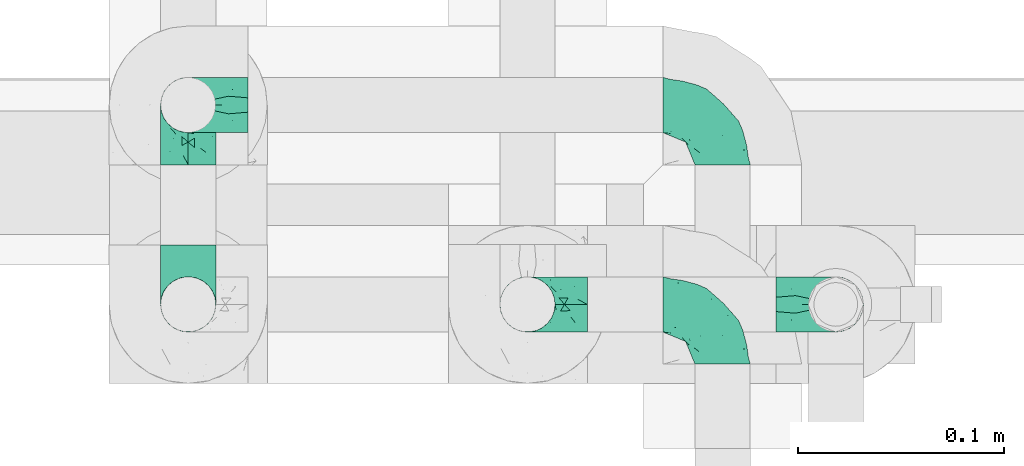
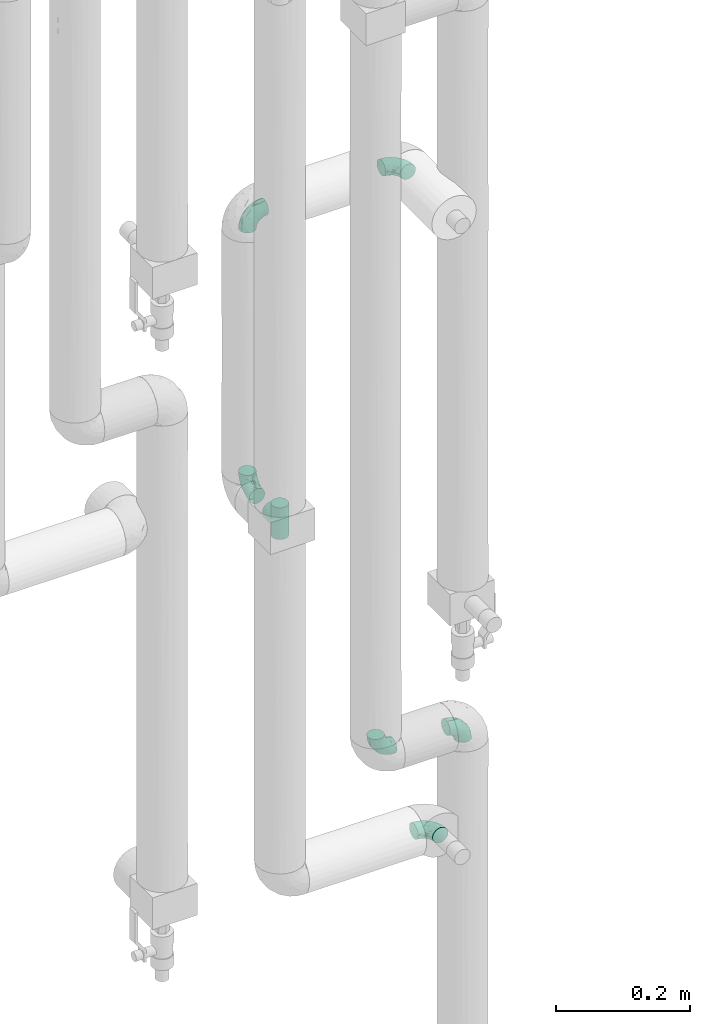
# One storey, part 755 of 827: 7 flow fittings.
"""IFC2X3 building model written with IfcOpenShell, lengths in millimetres."""

from ifc_helpers import new_model, entity, si_unit, converted_unit, derived_unit, direction, frame, origin, place, context, subcontext, project, spatial, faceted_brep, source, transform, mapped, material, type_object, type_shapes, element, save


model = new_model("IFC2X3")

# Units and contexts
model_context = context("Model", 3, precision=0.01, world=origin(), true_north=direction((6.12303176911189e-17, 1.0)))
body_context = subcontext(model_context, "Body", "Model", "MODEL_VIEW")
ifc_project = project(units=[si_unit("LENGTHUNIT", "METRE", prefix="MILLI"), si_unit("AREAUNIT", "SQUARE_METRE"), si_unit("VOLUMEUNIT", "CUBIC_METRE"), converted_unit("PLANEANGLEUNIT", "DEGREE", entity("IfcRatioMeasure", 0.0174532925199433), si_unit("PLANEANGLEUNIT", "RADIAN"), dimensions=[0, 0, 0, 0, 0, 0, 0]), si_unit("MASSUNIT", "GRAM", prefix="KILO"), derived_unit("MASSDENSITYUNIT", [(si_unit("MASSUNIT", "GRAM", prefix="KILO"), 1), (si_unit("LENGTHUNIT", "METRE"), -3)]), derived_unit("MOMENTOFINERTIAUNIT", [(si_unit("LENGTHUNIT", "METRE"), 4)]), si_unit("TIMEUNIT", "SECOND"), si_unit("FREQUENCYUNIT", "HERTZ"), si_unit("THERMODYNAMICTEMPERATUREUNIT", "DEGREE_CELSIUS"), derived_unit("THERMALTRANSMITTANCEUNIT", [(si_unit("MASSUNIT", "GRAM", prefix="KILO"), 1), (si_unit("THERMODYNAMICTEMPERATUREUNIT", "KELVIN"), -1), (si_unit("TIMEUNIT", "SECOND"), -3)]), derived_unit("VOLUMETRICFLOWRATEUNIT", [(si_unit("LENGTHUNIT", "METRE"), 3), (si_unit("TIMEUNIT", "SECOND"), -1)]), derived_unit("MASSFLOWRATEUNIT", [(si_unit("MASSUNIT", "GRAM", prefix="KILO"), 1), (si_unit("TIMEUNIT", "SECOND"), -1)]), derived_unit("ROTATIONALFREQUENCYUNIT", [(si_unit("TIMEUNIT", "SECOND"), -1)]), si_unit("ELECTRICCURRENTUNIT", "AMPERE"), si_unit("ELECTRICVOLTAGEUNIT", "VOLT"), si_unit("POWERUNIT", "WATT"), si_unit("FORCEUNIT", "NEWTON", prefix="KILO"), si_unit("ILLUMINANCEUNIT", "LUX"), si_unit("LUMINOUSFLUXUNIT", "LUMEN"), si_unit("LUMINOUSINTENSITYUNIT", "CANDELA"), derived_unit("USERDEFINED", [(si_unit("MASSUNIT", "GRAM", prefix="KILO"), -1), (si_unit("LENGTHUNIT", "METRE"), -2), (si_unit("TIMEUNIT", "SECOND"), 3), (si_unit("LUMINOUSFLUXUNIT", "LUMEN"), 1)]), derived_unit("LINEARVELOCITYUNIT", [(si_unit("LENGTHUNIT", "METRE"), 1), (si_unit("TIMEUNIT", "SECOND"), -1)]), si_unit("PRESSUREUNIT", "PASCAL"), derived_unit("USERDEFINED", [(si_unit("LENGTHUNIT", "METRE"), -2), (si_unit("MASSUNIT", "GRAM", prefix="KILO"), 1), (si_unit("TIMEUNIT", "SECOND"), -2)]), derived_unit("LINEARFORCEUNIT", [(si_unit("MASSUNIT", "GRAM", prefix="KILO"), 1), (si_unit("LENGTHUNIT", "METRE"), 1), (si_unit("TIMEUNIT", "SECOND"), -2), (si_unit("LENGTHUNIT", "METRE"), -1)]), derived_unit("PLANARFORCEUNIT", [(si_unit("MASSUNIT", "GRAM", prefix="KILO"), 1), (si_unit("LENGTHUNIT", "METRE"), 1), (si_unit("TIMEUNIT", "SECOND"), -2), (si_unit("LENGTHUNIT", "METRE"), -2)])], contexts=[model_context])

# Site, building, storey
site_placement = place(None, origin())
site = spatial("IfcSite", under=ifc_project, at=site_placement, CompositionType="ELEMENT")
building_placement = place(site_placement, origin())
building = spatial("IfcBuilding", under=site, at=building_placement, CompositionType="ELEMENT")
storey_placement = place(building_placement, frame((0.0, 0.0, 28200.0)))
storey = spatial("IfcBuildingStorey", under=building, at=storey_placement, Name="08", CompositionType="ELEMENT", Elevation=28200.0)

# Flow fittings
ifc_material = material()
pipe_fitting_type_1 = type_object("IfcPipeFittingType", Name="ADSK_1", PredefinedType="NOTDEFINED", material=ifc_material)
shared_shape_1 = source(origin(), body_context, "Body", "Brep", [
    faceted_brep([(-29.1, 0.0, -13.45), (-29.1, -3.48, -12.99), (-29.1, -6.73, -11.65), (-29.1, -9.51, -9.51), (-29.1, -11.65, -6.73), (-29.1, -12.99, -3.48), (-29.1, -13.45, 0.0), (-29.1, -12.99, 3.48), (-29.1, -11.65, 6.72), (-29.1, -9.51, 9.51), (-29.1, -6.73, 11.65), (-29.1, -3.48, 12.99), (-29.1, 0.0, 13.45), (-29.1, 3.48, 12.99), (-29.1, 6.72, 11.65), (-29.1, 9.51, 9.51), (-29.1, 11.65, 6.72), (-29.1, 12.99, 3.48), (-29.1, 13.45, 0.0), (-29.1, 12.99, -3.48), (-29.1, 11.65, -6.73), (-29.1, 9.51, -9.51), (-29.1, 6.72, -11.65), (-29.1, 3.48, -12.99), (-3.48, 29.1, -12.99), (-6.72, 29.1, -11.65), (-9.51, 29.1, -9.51), (-11.65, 29.1, -6.73), (-12.99, 29.1, -3.48), (-13.45, 29.1, 0.0), (-12.99, 29.1, 3.48), (-11.65, 29.1, 6.72), (-9.51, 29.1, 9.51), (-6.72, 29.1, 11.65), (-3.48, 29.1, 12.99), (0.0, 29.1, 13.45), (3.48, 29.1, 12.99), (6.73, 29.1, 11.65), (9.51, 29.1, 9.51), (11.65, 29.1, 6.72), (12.99, 29.1, 3.48), (13.45, 29.1, 0.0), (12.99, 29.1, -3.48), (11.65, 29.1, -6.73), (9.51, 29.1, -9.51), (6.73, 29.1, -11.65), (3.48, 29.1, -12.99), (0.0, 29.1, -13.45), (-19.62, -11.66, 4.28), (-21.41, -10.36, 7.6), (-16.26, -10.01, 0.0), (-12.48, -9.76, 2.75), (-10.66, 15.6, 11.91), (-15.27, 9.55, 12.42), (-10.71, 10.71, 13.09), (-0.04, 0.04, 0.0), (0.49, -0.45, 4.38), (-3.67, -4.15, 4.26), (-22.68, -11.73, 0.0), (-21.45, -4.97, 12.13), (-11.59, -2.84, 11.28), (-14.77, 0.17, 13.07), (-19.08, -7.58, 10.06), (-22.36, -1.69, 13.23), (-20.49, 2.21, 13.42), (-7.82, -7.75, 0.0), (-5.53, -2.55, 8.58), (-1.33, -0.87, 6.53), (-1.15, 1.15, 8.49), (-22.46, 5.38, 12.69), (-14.04, 21.05, 6.04), (-3.19, 3.19, 11.14), (-5.08, 25.05, 12.59), (-1.97, 21.79, 13.41), (-22.68, 11.31, 8.78), (-18.16, 12.64, 9.68), (-20.46, 14.33, 6.11), (-4.13, 10.11, 13.26), (-7.66, 3.08, 12.63), (-2.02, 8.24, 12.45), (-24.91, 8.22, 10.95), (-5.08, 14.28, 13.42), (-8.96, 6.48, 13.4), (-19.7, 16.14, 3.1), (-18.03, 18.03, 0.0), (-23.05, 15.96, 0.0), (-25.26, 12.69, 5.56), (4.97, 21.45, 12.13), (7.58, 19.08, 10.06), (1.69, 22.36, 13.23), (10.36, 21.41, 7.6), (8.11, 12.69, 6.86), (11.66, 19.62, 4.28), (-6.03, 19.65, 12.79), (9.76, 12.48, 2.75), (10.01, 16.26, 0.0), (-14.58, 16.06, 9.44), (-11.19, 23.14, 8.74), (-16.29, 16.8, 7.24), (-11.99, -5.68, 9.36), (-15.42, 20.78, 3.08), (5.79, 12.02, 9.27), (2.84, 11.59, 11.28), (2.55, 5.53, 8.58), (-15.74, 23.57, 0.0), (-15.96, 23.05, 0.0), (-24.62, 13.88, 2.39), (-8.61, 22.49, 11.12), (-14.98, 12.8, 11.14), (11.73, 22.68, 0.0), (-12.69, -8.11, 6.86), (7.75, 7.82, 0.0), (-15.98, 6.12, 13.19), (-14.48, 3.64, 13.45), (-19.6, 9.46, 11.31), (-8.3, 15.02, 12.85), (-0.17, 14.77, 13.07), (-6.9, -5.2, 6.52), (7.5, 8.93, 4.46), (5.22, 6.95, 6.56), (-8.85, -7.47, 4.42), (3.86, 3.93, 0.0), (4.18, 3.75, 4.31), (-23.57, 15.74, 0.0), (-3.93, -3.86, 0.0), (-21.79, 1.97, -13.41), (-11.31, 22.68, -8.78), (-14.33, 20.46, -6.11), (-12.69, 25.26, -5.56), (4.97, 21.45, -12.13), (2.84, 11.59, -11.28), (-0.17, 14.77, -13.07), (-25.05, 5.08, -12.59), (-16.8, 16.29, -7.24), (-20.78, 15.42, -3.08), (-16.14, 19.7, -3.1), (-12.02, -5.79, -9.27), (-11.59, -2.84, -11.28), (-5.53, -2.55, -8.58), (-23.14, 11.19, -8.74), (-22.49, 8.61, -11.12), (-1.33, -0.87, -6.53), (-3.67, -4.15, -4.26), (-6.9, -5.2, -6.52), (-19.65, 6.03, -12.79), (-15.6, 10.66, -11.91), (-14.28, 5.08, -13.42), (-10.71, 10.71, -13.09), (-6.48, 8.96, -13.4), (-19.62, -11.66, -4.28), (-21.41, -10.36, -7.6), (-12.48, -9.76, -2.75), (11.66, 19.62, -4.28), (-12.69, -8.11, -6.86), (-22.36, -1.69, -13.23), (-16.06, 14.58, -9.44), (5.68, 11.99, -9.36), (7.58, 19.08, -10.06), (-19.08, -7.58, -10.06), (-21.45, -4.97, -12.13), (-9.55, 15.27, -12.42), (-12.8, 14.98, -11.14), (-8.22, 24.91, -10.95), (10.36, 21.41, -7.6), (-5.38, 22.46, -12.69), (1.69, 22.36, -13.23), (-2.21, 20.49, -13.42), (-12.64, 18.16, -9.68), (-21.05, 14.04, -6.04), (9.76, 12.48, -2.75), (-10.11, 4.13, -13.26), (-3.08, 7.66, -12.63), (-8.24, 2.02, -12.45), (-13.88, 24.62, -2.39), (8.11, 12.69, -6.86), (-6.12, 15.98, -13.19), (-3.64, 14.48, -13.45), (-9.46, 19.6, -11.31), (-15.02, 8.3, -12.85), (-14.77, 0.17, -13.07), (-3.19, 3.19, -11.14), (5.22, 6.95, -6.56), (2.55, 5.53, -8.58), (0.49, -0.45, -4.38), (4.18, 3.75, -4.31), (-8.85, -7.47, -4.42), (-1.15, 1.15, -8.49), (7.5, 8.93, -4.46)], [[[0, 1, 2, 3, 4, 5, 6, 7, 8, 9, 10, 11, 12, 13, 14, 15, 16, 17, 18, 19, 20, 21, 22, 23]], [[24, 25, 26, 27, 28, 29, 30, 31, 32, 33, 34, 35, 36, 37, 38, 39, 40, 41, 42, 43, 44, 45, 46, 47]], [[48, 49, 8]], [[48, 50, 51]], [[52, 53, 54]], [[55, 56, 57]], [[49, 9, 8]], [[58, 48, 7]], [[59, 60, 61]], [[62, 10, 9]], [[62, 59, 10]], [[12, 63, 64]], [[51, 50, 65]], [[66, 67, 68]], [[12, 11, 63]], [[69, 14, 13]], [[31, 30, 70]], [[66, 71, 60]], [[34, 72, 73]], [[74, 75, 76]], [[77, 78, 79]], [[14, 80, 15]], [[16, 15, 74]], [[81, 54, 82]], [[83, 84, 85]], [[74, 76, 86]], [[37, 87, 88]], [[88, 38, 37]], [[36, 35, 89]], [[90, 91, 92]], [[93, 81, 73]], [[35, 34, 73]], [[10, 59, 11]], [[92, 94, 95]], [[96, 97, 98]], [[90, 92, 39]], [[99, 60, 62]], [[40, 39, 92]], [[87, 37, 36]], [[100, 84, 83]], [[50, 48, 58]], [[100, 83, 98]], [[101, 102, 103]], [[104, 105, 84, 100, 29]], [[48, 8, 7]], [[86, 17, 16]], [[106, 18, 17]], [[32, 97, 107]], [[53, 52, 108]], [[52, 93, 107]], [[97, 96, 107]], [[72, 107, 93]], [[72, 34, 33]], [[92, 109, 40]], [[33, 32, 107]], [[69, 13, 64]], [[88, 87, 102]], [[12, 64, 13]], [[49, 110, 62]], [[39, 38, 90]], [[95, 94, 111]], [[112, 113, 82]], [[53, 69, 112]], [[80, 74, 15]], [[114, 108, 75]], [[32, 31, 97]], [[115, 52, 54]], [[93, 115, 81]], [[89, 73, 116]], [[106, 76, 83]], [[106, 83, 85]], [[83, 76, 98]], [[100, 30, 29]], [[60, 59, 62]], [[63, 59, 61]], [[110, 117, 99]], [[60, 71, 78]], [[89, 87, 36]], [[116, 79, 102]], [[116, 102, 87]], [[102, 71, 103]], [[110, 49, 48]], [[62, 9, 49]], [[38, 88, 90]], [[91, 90, 88]], [[112, 69, 64]], [[80, 69, 114]], [[111, 94, 118]], [[119, 101, 103]], [[117, 66, 99]], [[117, 120, 57]], [[119, 91, 101]], [[66, 68, 71]], [[66, 117, 67]], [[121, 111, 122, 55]], [[56, 55, 122]], [[31, 70, 97]], [[97, 70, 98]], [[107, 96, 52]], [[53, 108, 114]], [[112, 82, 54]], [[116, 73, 81]], [[78, 82, 61]], [[81, 82, 77]], [[73, 89, 35]], [[87, 89, 116]], [[59, 63, 11]], [[64, 63, 61]], [[112, 64, 113]], [[53, 112, 54]], [[7, 6, 58]], [[109, 92, 95]], [[109, 41, 40]], [[69, 53, 114]], [[52, 96, 108]], [[75, 108, 96]], [[75, 96, 98]], [[114, 75, 74]], [[64, 61, 113]], [[61, 82, 113]], [[91, 88, 101]], [[110, 48, 51]], [[92, 91, 94]], [[91, 119, 118]], [[106, 85, 123, 18]], [[106, 17, 86]], [[60, 78, 61]], [[79, 78, 71]], [[102, 79, 71]], [[77, 79, 116]], [[81, 77, 116]], [[78, 77, 82]], [[69, 80, 14]], [[74, 80, 114]], [[74, 86, 16]], [[106, 86, 76]], [[107, 72, 33]], [[73, 72, 93]], [[98, 70, 100]], [[75, 98, 76]], [[30, 100, 70]], [[110, 99, 62]], [[66, 60, 99]], [[120, 110, 51]], [[67, 117, 57]], [[57, 56, 67]], [[67, 122, 119]], [[110, 120, 117]], [[65, 120, 51]], [[57, 65, 124, 55]], [[122, 67, 56]], [[67, 103, 68]], [[71, 68, 103]], [[65, 57, 120]], [[102, 101, 88]], [[67, 119, 103]], [[118, 119, 122]], [[118, 122, 111]], [[91, 118, 94]], [[81, 115, 54]], [[93, 52, 115]], [[23, 125, 0]], [[126, 127, 128]], [[129, 130, 131]], [[23, 22, 132]], [[133, 134, 135]], [[136, 137, 138]], [[21, 139, 140]], [[141, 142, 143]], [[144, 140, 145]], [[143, 136, 138]], [[146, 147, 148]], [[144, 132, 140]], [[5, 4, 149]], [[4, 3, 150]], [[45, 129, 46]], [[151, 50, 149]], [[152, 43, 42]], [[42, 41, 109]], [[150, 149, 4]], [[153, 149, 150]], [[154, 1, 0]], [[139, 155, 140]], [[156, 130, 157]], [[149, 58, 5]], [[18, 123, 85, 84, 134]], [[158, 159, 137]], [[84, 105, 135]], [[160, 145, 161]], [[143, 153, 136]], [[27, 26, 126]], [[25, 162, 26]], [[152, 163, 43]], [[25, 24, 164]], [[47, 165, 166]], [[158, 3, 2]], [[167, 127, 126]], [[20, 19, 168]], [[47, 46, 165]], [[44, 157, 45]], [[23, 132, 125]], [[44, 43, 163]], [[158, 2, 159]], [[47, 166, 24]], [[129, 45, 157]], [[164, 24, 166]], [[134, 84, 135]], [[95, 169, 152]], [[22, 21, 140]], [[144, 146, 125]], [[109, 152, 42]], [[95, 152, 109]], [[170, 171, 172]], [[155, 139, 133]], [[28, 27, 128]], [[159, 2, 1]], [[173, 29, 28]], [[50, 151, 65]], [[169, 95, 111]], [[163, 174, 157]], [[175, 176, 148]], [[160, 164, 175]], [[162, 126, 26]], [[177, 161, 167]], [[21, 20, 139]], [[144, 145, 178]], [[144, 178, 146]], [[154, 125, 179]], [[173, 127, 135]], [[173, 135, 105]], [[135, 127, 133]], [[134, 19, 18]], [[154, 159, 1]], [[179, 172, 137]], [[179, 137, 159]], [[137, 180, 138]], [[130, 129, 157]], [[165, 129, 131]], [[174, 181, 156]], [[130, 180, 171]], [[3, 158, 150]], [[153, 150, 158]], [[174, 163, 152]], [[157, 44, 163]], [[175, 164, 166]], [[162, 164, 177]], [[130, 182, 180]], [[181, 141, 182]], [[55, 183, 184]], [[65, 151, 185]], [[183, 55, 142]], [[156, 181, 182]], [[180, 182, 186]], [[181, 187, 184]], [[65, 142, 55, 124]], [[20, 168, 139]], [[139, 168, 133]], [[140, 155, 145]], [[160, 161, 177]], [[175, 148, 147]], [[179, 125, 146]], [[171, 148, 131]], [[146, 148, 170]], [[125, 154, 0]], [[159, 154, 179]], [[129, 165, 46]], [[166, 165, 131]], [[175, 166, 176]], [[160, 175, 147]], [[58, 149, 50]], [[58, 6, 5]], [[145, 160, 147]], [[164, 160, 177]], [[145, 155, 161]], [[167, 161, 155]], [[167, 155, 133]], [[177, 167, 126]], [[166, 131, 176]], [[131, 148, 176]], [[149, 153, 151]], [[153, 143, 185]], [[145, 147, 178]], [[174, 152, 169]], [[173, 105, 104, 29]], [[173, 28, 128]], [[130, 171, 131]], [[172, 171, 180]], [[137, 172, 180]], [[170, 172, 179]], [[146, 170, 179]], [[171, 170, 148]], [[164, 162, 25]], [[126, 162, 177]], [[126, 128, 27]], [[173, 128, 127]], [[140, 132, 22]], [[125, 132, 144]], [[133, 168, 134]], [[167, 133, 127]], [[19, 134, 168]], [[153, 158, 136]], [[137, 136, 158]], [[141, 143, 138]], [[185, 143, 142]], [[186, 141, 138]], [[183, 142, 141]], [[185, 142, 65]], [[153, 185, 151]], [[180, 186, 138]], [[182, 141, 186]], [[141, 184, 183]], [[184, 111, 121, 55]], [[174, 156, 157]], [[182, 130, 156]], [[187, 174, 169]], [[141, 181, 184]], [[174, 187, 181]], [[111, 187, 169]], [[111, 184, 187]], [[146, 178, 147]]]),
])
type_shapes(pipe_fitting_type_1, [shared_shape_1])
for number, where, z_axis, x_axis, name in (
    (1, (35142.88, 14924.91, 1230.0), (0.0, 1.0, 0.0), (1.0, 0.0, 0.0), "ADSK_1"),
    (2, (34992.88, 14924.91, 1230.0), (0.0, 1.0, 0.0), (-1.0, 0.0, 0.0), "ADSK_1"),
):
    element("IfcFlowFitting", number, at=place(storey_placement, frame(where, z_axis=z_axis, x_axis=x_axis)), inside=storey, type_object=pipe_fitting_type_1, material=ifc_material, Name=name, ObjectType="ADSK_1", context=body_context, shape_type="MappedRepresentation", body=[
        mapped(shared_shape_1, transform((0.0, 0.0, 0.0), scale=1.0)),
    ])
pipe_fitting_type_2 = type_object("IfcPipeFittingType", Name="ADSK_1", PredefinedType="NOTDEFINED", material=ifc_material)
shared_shape_2 = source(origin(), body_context, "Body", "Brep", [
    faceted_brep([(-29.1, -3.48, -12.99), (-29.1, -6.72, -11.65), (-29.1, -9.51, -9.51), (-29.1, -11.65, -6.73), (-29.1, -12.99, -3.48), (-29.1, -13.45, 0.0), (-29.1, -12.99, 3.48), (-29.1, -11.65, 6.72), (-29.1, -9.51, 9.51), (-29.1, -6.72, 11.65), (-29.1, -3.48, 12.99), (-29.1, 0.0, 13.45), (-29.1, 3.48, 12.99), (-29.1, 6.73, 11.65), (-29.1, 9.51, 9.51), (-29.1, 11.65, 6.72), (-29.1, 12.99, 3.48), (-29.1, 13.45, 0.0), (-29.1, 12.99, -3.48), (-29.1, 11.65, -6.73), (-29.1, 9.51, -9.51), (-29.1, 6.73, -11.65), (-29.1, 3.48, -12.99), (-29.1, 0.0, -13.45), (0.0, -29.1, -13.45), (3.48, -29.1, -12.99), (6.73, -29.1, -11.65), (9.51, -29.1, -9.51), (11.65, -29.1, -6.73), (12.99, -29.1, -3.48), (13.45, -29.1, 0.0), (12.99, -29.1, 3.48), (11.65, -29.1, 6.72), (9.51, -29.1, 9.51), (6.73, -29.1, 11.65), (3.48, -29.1, 12.99), (0.0, -29.1, 13.45), (-3.48, -29.1, 12.99), (-6.72, -29.1, 11.65), (-9.51, -29.1, 9.51), (-11.65, -29.1, 6.72), (-12.99, -29.1, 3.48), (-13.45, -29.1, 0.0), (-12.99, -29.1, -3.48), (-11.65, -29.1, -6.73), (-9.51, -29.1, -9.51), (-6.72, -29.1, -11.65), (-3.48, -29.1, -12.99), (-21.41, 10.36, 7.6), (-19.62, 11.66, 4.28), (-12.48, 9.76, 2.75), (-16.26, 10.01, 0.0), (-10.71, -10.71, 13.09), (-15.27, -9.55, 12.42), (-10.66, -15.6, 11.91), (-3.67, 4.15, 4.26), (0.49, 0.45, 4.38), (-0.04, -0.04, 0.0), (-22.68, 11.73, 0.0), (-14.77, -0.17, 13.07), (-11.59, 2.84, 11.28), (-21.45, 4.97, 12.13), (-19.08, 7.58, 10.06), (-20.49, -2.21, 13.42), (-22.36, 1.69, 13.23), (-7.82, 7.75, 0.0), (-1.15, -1.15, 8.49), (-1.33, 0.87, 6.53), (-5.53, 2.55, 8.58), (-22.46, -5.38, 12.69), (-14.04, -21.05, 6.04), (-3.19, -3.19, 11.14), (-1.97, -21.79, 13.41), (-5.08, -25.05, 12.59), (-20.46, -14.33, 6.11), (-18.16, -12.64, 9.68), (-22.68, -11.31, 8.78), (-2.02, -8.24, 12.45), (-7.66, -3.08, 12.63), (-4.13, -10.11, 13.26), (-24.91, -8.22, 10.95), (-8.96, -6.48, 13.4), (-5.08, -14.28, 13.42), (-23.05, -15.96, 0.0), (-18.03, -18.03, 0.0), (-19.7, -16.14, 3.1), (-25.26, -12.69, 5.56), (7.58, -19.08, 10.06), (4.97, -21.45, 12.13), (1.69, -22.36, 13.23), (11.66, -19.62, 4.28), (8.11, -12.69, 6.86), (10.36, -21.41, 7.6), (-6.03, -19.65, 12.79), (10.01, -16.26, 0.0), (9.76, -12.48, 2.75), (-16.29, -16.8, 7.24), (-11.19, -23.14, 8.74), (-14.58, -16.06, 9.44), (-11.99, 5.68, 9.36), (-15.42, -20.78, 3.08), (2.55, -5.53, 8.58), (2.84, -11.59, 11.28), (5.79, -12.02, 9.27), (-15.96, -23.05, 0.0), (-15.74, -23.57, 0.0), (-24.62, -13.88, 2.39), (-8.61, -22.49, 11.12), (-14.98, -12.8, 11.14), (11.73, -22.68, 0.0), (-12.69, 8.11, 6.86), (7.75, -7.82, 0.0), (-14.48, -3.64, 13.45), (-15.98, -6.12, 13.19), (-19.6, -9.46, 11.31), (-8.3, -15.02, 12.85), (-0.17, -14.77, 13.07), (-6.9, 5.2, 6.52), (7.5, -8.93, 4.46), (5.22, -6.95, 6.56), (-8.85, 7.47, 4.42), (4.18, -3.75, 4.31), (3.86, -3.93, 0.0), (-23.57, -15.74, 0.0), (-3.93, 3.86, 0.0), (-21.79, -1.97, -13.41), (-12.69, -25.26, -5.56), (-14.33, -20.46, -6.11), (-11.31, -22.68, -8.78), (-0.17, -14.77, -13.07), (2.84, -11.59, -11.28), (4.97, -21.45, -12.13), (-25.05, -5.08, -12.59), (-16.14, -19.7, -3.1), (-20.78, -15.42, -3.08), (-16.8, -16.29, -7.24), (-5.53, 2.55, -8.58), (-11.59, 2.84, -11.28), (-12.02, 5.79, -9.27), (-22.49, -8.61, -11.12), (-23.14, -11.19, -8.74), (-6.9, 5.2, -6.52), (-3.67, 4.15, -4.26), (-1.33, 0.87, -6.53), (-15.6, -10.66, -11.91), (-19.65, -6.03, -12.79), (-6.48, -8.96, -13.4), (-10.71, -10.71, -13.09), (-14.28, -5.08, -13.42), (-19.62, 11.66, -4.28), (-21.41, 10.36, -7.6), (-12.48, 9.76, -2.75), (11.66, -19.62, -4.28), (-12.69, 8.11, -6.86), (-22.36, 1.69, -13.23), (-16.06, -14.58, -9.44), (7.58, -19.08, -10.06), (5.68, -11.99, -9.36), (-21.45, 4.97, -12.13), (-19.08, 7.58, -10.06), (-12.8, -14.98, -11.14), (-9.55, -15.27, -12.42), (-8.22, -24.91, -10.95), (10.36, -21.41, -7.6), (-5.38, -22.46, -12.69), (-2.21, -20.49, -13.42), (1.69, -22.36, -13.23), (-12.64, -18.16, -9.68), (-21.05, -14.04, -6.04), (9.76, -12.48, -2.75), (-8.24, -2.02, -12.45), (-3.08, -7.66, -12.63), (-10.11, -4.13, -13.26), (-13.88, -24.62, -2.39), (8.11, -12.69, -6.86), (-3.64, -14.48, -13.45), (-6.12, -15.98, -13.19), (-9.46, -19.6, -11.31), (-15.02, -8.3, -12.85), (-14.77, -0.17, -13.07), (-3.19, -3.19, -11.14), (5.22, -6.95, -6.56), (2.55, -5.53, -8.58), (4.18, -3.75, -4.31), (0.49, 0.45, -4.38), (-8.85, 7.47, -4.42), (-1.15, -1.15, -8.49), (7.5, -8.93, -4.46)], [[[0, 1, 2, 3, 4, 5, 6, 7, 8, 9, 10, 11, 12, 13, 14, 15, 16, 17, 18, 19, 20, 21, 22, 23]], [[24, 25, 26, 27, 28, 29, 30, 31, 32, 33, 34, 35, 36, 37, 38, 39, 40, 41, 42, 43, 44, 45, 46, 47]], [[15, 48, 49]], [[50, 51, 49]], [[52, 53, 54]], [[55, 56, 57]], [[15, 14, 48]], [[16, 49, 58]], [[59, 60, 61]], [[14, 13, 62]], [[13, 61, 62]], [[63, 64, 11]], [[65, 51, 50]], [[66, 67, 68]], [[64, 12, 11]], [[10, 9, 69]], [[70, 41, 40]], [[60, 71, 68]], [[72, 73, 37]], [[74, 75, 76]], [[77, 78, 79]], [[8, 80, 9]], [[76, 8, 7]], [[81, 52, 82]], [[83, 84, 85]], [[86, 74, 76]], [[87, 88, 34]], [[34, 33, 87]], [[89, 36, 35]], [[90, 91, 92]], [[72, 82, 93]], [[72, 37, 36]], [[12, 61, 13]], [[94, 95, 90]], [[96, 97, 98]], [[32, 90, 92]], [[62, 60, 99]], [[90, 32, 31]], [[35, 34, 88]], [[85, 84, 100]], [[58, 49, 51]], [[96, 85, 100]], [[101, 102, 103]], [[42, 100, 84, 104, 105]], [[16, 15, 49]], [[7, 6, 86]], [[6, 5, 106]], [[107, 97, 39]], [[108, 54, 53]], [[107, 93, 54]], [[107, 98, 97]], [[93, 107, 73]], [[38, 37, 73]], [[31, 109, 90]], [[107, 39, 38]], [[63, 10, 69]], [[102, 88, 87]], [[10, 63, 11]], [[62, 110, 48]], [[92, 33, 32]], [[111, 95, 94]], [[81, 112, 113]], [[113, 69, 53]], [[8, 76, 80]], [[75, 108, 114]], [[97, 40, 39]], [[52, 54, 115]], [[82, 115, 93]], [[116, 72, 89]], [[85, 74, 106]], [[83, 85, 106]], [[96, 74, 85]], [[42, 41, 100]], [[62, 61, 60]], [[59, 61, 64]], [[99, 117, 110]], [[78, 71, 60]], [[35, 88, 89]], [[102, 77, 116]], [[88, 102, 116]], [[101, 71, 102]], [[49, 48, 110]], [[48, 14, 62]], [[92, 87, 33]], [[87, 92, 91]], [[63, 69, 113]], [[114, 69, 80]], [[118, 95, 111]], [[101, 103, 119]], [[99, 68, 117]], [[55, 120, 117]], [[103, 91, 119]], [[71, 66, 68]], [[67, 117, 68]], [[121, 111, 122, 57]], [[121, 57, 56]], [[97, 70, 40]], [[96, 70, 97]], [[54, 98, 107]], [[114, 108, 53]], [[52, 81, 113]], [[82, 72, 116]], [[59, 81, 78]], [[79, 81, 82]], [[36, 89, 72]], [[116, 89, 88]], [[12, 64, 61]], [[59, 64, 63]], [[112, 63, 113]], [[52, 113, 53]], [[58, 17, 16]], [[94, 90, 109]], [[31, 30, 109]], [[114, 53, 69]], [[108, 98, 54]], [[98, 108, 75]], [[96, 98, 75]], [[76, 75, 114]], [[112, 59, 63]], [[112, 81, 59]], [[103, 87, 91]], [[50, 49, 110]], [[95, 91, 90]], [[118, 119, 91]], [[106, 5, 123, 83]], [[86, 6, 106]], [[59, 78, 60]], [[71, 78, 77]], [[71, 77, 102]], [[116, 77, 79]], [[116, 79, 82]], [[81, 79, 78]], [[9, 80, 69]], [[114, 80, 76]], [[7, 86, 76]], [[74, 86, 106]], [[38, 73, 107]], [[93, 73, 72]], [[100, 70, 96]], [[74, 96, 75]], [[70, 100, 41]], [[62, 99, 110]], [[99, 60, 68]], [[50, 110, 120]], [[55, 117, 67]], [[67, 56, 55]], [[119, 121, 67]], [[117, 120, 110]], [[50, 120, 65]], [[124, 65, 55, 57]], [[56, 67, 121]], [[66, 101, 67]], [[101, 66, 71]], [[120, 55, 65]], [[87, 103, 102]], [[101, 119, 67]], [[121, 119, 118]], [[111, 121, 118]], [[95, 118, 91]], [[52, 115, 82]], [[115, 54, 93]], [[23, 125, 0]], [[126, 127, 128]], [[129, 130, 131]], [[132, 1, 0]], [[133, 134, 135]], [[136, 137, 138]], [[139, 140, 2]], [[141, 142, 143]], [[144, 139, 145]], [[136, 138, 141]], [[146, 147, 148]], [[139, 132, 145]], [[149, 19, 18]], [[150, 20, 19]], [[25, 131, 26]], [[149, 51, 151]], [[29, 28, 152]], [[109, 30, 29]], [[19, 149, 150]], [[150, 149, 153]], [[23, 22, 154]], [[139, 155, 140]], [[156, 130, 157]], [[18, 58, 149]], [[134, 84, 83, 123, 5]], [[137, 158, 159]], [[133, 104, 84]], [[160, 144, 161]], [[138, 153, 141]], [[128, 45, 44]], [[45, 162, 46]], [[28, 163, 152]], [[164, 47, 46]], [[165, 166, 24]], [[21, 20, 159]], [[128, 127, 167]], [[168, 4, 3]], [[166, 25, 24]], [[26, 156, 27]], [[125, 132, 0]], [[163, 28, 27]], [[158, 21, 159]], [[47, 165, 24]], [[156, 26, 131]], [[165, 47, 164]], [[133, 84, 134]], [[152, 169, 94]], [[139, 2, 1]], [[125, 148, 145]], [[29, 152, 109]], [[109, 152, 94]], [[170, 171, 172]], [[135, 140, 155]], [[126, 44, 43]], [[22, 21, 158]], [[43, 42, 173]], [[65, 151, 51]], [[111, 94, 169]], [[156, 174, 163]], [[146, 175, 176]], [[176, 164, 161]], [[45, 128, 162]], [[167, 160, 177]], [[140, 3, 2]], [[178, 144, 145]], [[148, 178, 145]], [[179, 125, 154]], [[133, 127, 173]], [[104, 133, 173]], [[135, 127, 133]], [[5, 4, 134]], [[22, 158, 154]], [[137, 170, 179]], [[158, 137, 179]], [[136, 180, 137]], [[156, 131, 130]], [[129, 131, 166]], [[157, 181, 174]], [[171, 180, 130]], [[150, 159, 20]], [[159, 150, 153]], [[152, 163, 174]], [[163, 27, 156]], [[165, 164, 176]], [[177, 164, 162]], [[180, 182, 130]], [[182, 143, 181]], [[183, 184, 57]], [[185, 151, 65]], [[142, 57, 184]], [[182, 181, 157]], [[186, 182, 180]], [[183, 187, 181]], [[124, 57, 142, 65]], [[140, 168, 3]], [[135, 168, 140]], [[144, 155, 139]], [[177, 160, 161]], [[147, 146, 176]], [[148, 125, 179]], [[129, 146, 171]], [[172, 146, 148]], [[23, 154, 125]], [[179, 154, 158]], [[25, 166, 131]], [[129, 166, 165]], [[175, 165, 176]], [[147, 176, 161]], [[51, 149, 58]], [[18, 17, 58]], [[147, 161, 144]], [[177, 161, 164]], [[160, 155, 144]], [[155, 160, 167]], [[135, 155, 167]], [[128, 167, 177]], [[175, 129, 165]], [[175, 146, 129]], [[151, 153, 149]], [[185, 141, 153]], [[178, 147, 144]], [[169, 152, 174]], [[173, 42, 105, 104]], [[126, 43, 173]], [[129, 171, 130]], [[180, 171, 170]], [[180, 170, 137]], [[179, 170, 172]], [[179, 172, 148]], [[146, 172, 171]], [[46, 162, 164]], [[177, 162, 128]], [[44, 126, 128]], [[127, 126, 173]], [[1, 132, 139]], [[145, 132, 125]], [[134, 168, 135]], [[127, 135, 167]], [[168, 134, 4]], [[138, 159, 153]], [[159, 138, 137]], [[136, 141, 143]], [[142, 141, 185]], [[136, 143, 186]], [[143, 142, 184]], [[65, 142, 185]], [[151, 185, 153]], [[136, 186, 180]], [[186, 143, 182]], [[184, 183, 143]], [[122, 111, 183, 57]], [[156, 157, 174]], [[157, 130, 182]], [[169, 174, 187]], [[183, 181, 143]], [[181, 187, 174]], [[169, 187, 111]], [[187, 183, 111]], [[147, 178, 148]]]),
])
type_shapes(pipe_fitting_type_2, [shared_shape_2])
flow_fitting_1_placement = place(storey_placement, frame((35087.85, 14924.91, 1060.0)))
element("IfcFlowFitting", 3, at=flow_fitting_1_placement, inside=storey, type_object=pipe_fitting_type_2, material=ifc_material, Name="ADSK_1", ObjectType="ADSK_1", context=body_context, shape_type="MappedRepresentation", body=[
    mapped(shared_shape_2, transform((0.0, 0.0, 0.0), scale=1.0)),
])
for number, where, z_axis, x_axis, name in (
    (4, (34827.85, 15021.91, 2210.0), (0.0, 1.0, 0.0), (-1.0, 0.0, 0.0), "ADSK_1"),
    (5, (34827.85, 15021.91, 1710.0), (-1.0, 0.0, 0.0), (0.0, 1.0, 0.0), "ADSK_1"),
):
    element("IfcFlowFitting", number, at=place(storey_placement, frame(where, z_axis=z_axis, x_axis=x_axis)), inside=storey, type_object=pipe_fitting_type_2, material=ifc_material, Name=name, ObjectType="ADSK_1", context=body_context, shape_type="MappedRepresentation", body=[
        mapped(shared_shape_2, transform((0.0, 0.0, 0.0), scale=1.0)),
    ])
flow_fitting_2_placement = place(storey_placement, frame((35087.85, 15021.91, 2210.0)))
element("IfcFlowFitting", 6, at=flow_fitting_2_placement, inside=storey, type_object=pipe_fitting_type_2, material=ifc_material, Name="ADSK_1", ObjectType="ADSK_1", context=body_context, shape_type="MappedRepresentation", body=[
    mapped(shared_shape_2, transform((0.0, 0.0, 0.0), scale=1.0)),
])
pipe_fitting_type_3 = type_object("IfcPipeFittingType", Name="ADSK_1", PredefinedType="NOTDEFINED", material=ifc_material)
shared_shape_3 = source(origin(), body_context, "Body", "Brep", [
    faceted_brep([(-29.0, -11.65, -6.73), (-29.0, -12.99, -3.48), (-29.0, -13.45, 0.0), (-29.0, -12.99, 3.48), (-29.0, -11.65, 6.72), (-29.0, -9.51, 9.51), (-29.0, -6.72, 11.65), (-29.0, -3.48, 12.99), (-29.0, 0.0, 13.45), (-29.0, 3.48, 12.99), (-29.0, 6.73, 11.65), (-29.0, 9.51, 9.51), (-29.0, 11.65, 6.72), (-29.0, 12.99, 3.48), (-29.0, 13.45, 0.0), (-29.0, 12.99, -3.48), (-29.0, 11.65, -6.73), (-29.0, 9.51, -9.51), (-29.0, 6.73, -11.65), (-29.0, 3.48, -12.99), (-29.0, 0.0, -13.45), (-29.0, -3.48, -12.99), (-29.0, -6.72, -11.65), (-29.0, -9.51, -9.51), (29.0, -3.48, -12.99), (29.0, 0.0, -13.45), (29.0, 3.48, -12.99), (29.0, 6.73, -11.65), (29.0, 9.51, -9.51), (29.0, 11.65, -6.73), (29.0, 12.99, -3.48), (29.0, 13.45, 0.0), (29.0, 12.99, 3.48), (29.0, 11.65, 6.72), (29.0, 9.51, 9.51), (29.0, 6.73, 11.65), (29.0, 3.48, 12.99), (29.0, 0.0, 13.45), (29.0, -3.48, 12.99), (29.0, -6.72, 11.65), (29.0, -9.51, 9.51), (29.0, -11.65, 6.72), (29.0, -12.99, 3.48), (29.0, -13.45, 0.0), (29.0, -12.99, -3.48), (29.0, -11.65, -6.73), (29.0, -9.51, -9.51), (29.0, -6.72, -11.65), (12.96, 12.96, 3.59), (13.45, 13.45, 0.0), (-13.45, 13.45, 0.0), (11.64, 11.64, 6.74), (7.54, 7.54, 11.14), (9.76, 9.76, 9.25), (-12.96, 12.96, 3.59), (-11.64, 11.64, 6.74), (-7.54, 7.54, 11.14), (-9.76, 9.76, 9.25), (-5.12, 5.12, 12.44), (5.12, 5.12, 12.44), (0.0, 0.0, 13.45), (2.58, 2.58, 13.2), (-2.58, 2.58, 13.2), (2.58, 2.58, -13.2), (0.0, 0.0, -13.45), (-2.58, 2.58, -13.2), (-5.12, 5.12, -12.44), (5.12, 5.12, -12.44), (7.54, 7.54, -11.14), (9.76, 9.76, -9.25), (11.64, 11.64, -6.74), (12.96, 12.96, -3.59), (-7.54, 7.54, -11.14), (-9.76, 9.76, -9.25), (-12.96, 12.96, -3.59), (-11.64, 11.64, -6.74), (3.48, 29.0, -12.99), (0.0, 29.0, -13.45), (-3.48, 29.0, -12.99), (-6.72, 29.0, -11.65), (-9.51, 29.0, -9.51), (-11.65, 29.0, -6.73), (-12.99, 29.0, -3.48), (-13.45, 29.0, 0.0), (-12.99, 29.0, 3.48), (-11.65, 29.0, 6.72), (-9.51, 29.0, 9.51), (-6.72, 29.0, 11.65), (-3.48, 29.0, 12.99), (0.0, 29.0, 13.45), (3.48, 29.0, 12.99), (6.73, 29.0, 11.65), (9.51, 29.0, 9.51), (11.65, 29.0, 6.72), (12.99, 29.0, 3.48), (13.45, 29.0, 0.0), (12.99, 29.0, -3.48), (11.65, 29.0, -6.73), (9.51, 29.0, -9.51), (6.73, 29.0, -11.65)], [[[0, 1, 2, 3, 4, 5, 6, 7, 8, 9, 10, 11, 12, 13, 14, 15, 16, 17, 18, 19, 20, 21, 22, 23]], [[24, 25, 26, 27, 28, 29, 30, 31, 32, 33, 34, 35, 36, 37, 38, 39, 40, 41, 42, 43, 44, 45, 46, 47]], [[48, 33, 32]], [[49, 32, 31]], [[14, 13, 50]], [[48, 32, 49]], [[48, 51, 33]], [[52, 35, 34]], [[53, 33, 51]], [[34, 53, 52]], [[34, 33, 53]], [[13, 54, 50]], [[12, 54, 13]], [[12, 55, 54]], [[11, 56, 57]], [[57, 12, 11]], [[10, 56, 11]], [[55, 12, 57]], [[58, 56, 10]], [[59, 35, 52]], [[60, 37, 61]], [[8, 60, 62]], [[61, 36, 59]], [[35, 59, 36]], [[37, 36, 61]], [[38, 37, 60, 8, 7]], [[3, 42, 41, 4]], [[40, 39, 6, 5]], [[41, 40, 5, 4]], [[6, 39, 38, 7]], [[43, 42, 3, 2]], [[58, 9, 62]], [[8, 62, 9]], [[10, 9, 58]], [[45, 0, 23, 46]], [[43, 2, 1, 44]], [[0, 45, 44, 1]], [[47, 46, 23, 22]], [[63, 26, 25]], [[24, 21, 20, 64, 25]], [[63, 25, 64]], [[65, 64, 20]], [[21, 24, 47, 22]], [[19, 66, 65]], [[19, 65, 20]], [[19, 18, 66]], [[67, 26, 63]], [[68, 28, 27]], [[28, 68, 69]], [[69, 70, 29]], [[29, 28, 69]], [[67, 68, 27]], [[49, 31, 30]], [[14, 50, 15]], [[29, 71, 30]], [[49, 30, 71]], [[70, 71, 29]], [[66, 18, 72]], [[18, 17, 72]], [[73, 72, 17]], [[16, 73, 17]], [[15, 50, 74]], [[16, 74, 75]], [[16, 15, 74]], [[73, 16, 75]], [[26, 67, 27]], [[76, 77, 78, 79, 80, 81, 82, 83, 84, 85, 86, 87, 88, 89, 90, 91, 92, 93, 94, 95, 96, 97, 98, 99]], [[50, 84, 83]], [[84, 50, 54]], [[56, 87, 86]], [[57, 86, 85]], [[84, 54, 85]], [[88, 87, 58]], [[85, 54, 55]], [[85, 55, 57]], [[87, 56, 58]], [[62, 60, 89]], [[62, 88, 58]], [[56, 86, 57]], [[89, 88, 62]], [[90, 89, 61]], [[90, 59, 91]], [[48, 94, 93]], [[93, 92, 53]], [[92, 91, 52]], [[95, 94, 49]], [[90, 61, 59]], [[91, 59, 52]], [[94, 48, 49]], [[93, 53, 51]], [[93, 51, 48]], [[53, 92, 52]], [[60, 61, 89]], [[49, 96, 95]], [[96, 49, 71]], [[98, 97, 69]], [[99, 98, 68]], [[71, 97, 96]], [[76, 99, 67]], [[97, 71, 70]], [[97, 70, 69]], [[99, 68, 67]], [[63, 64, 77]], [[63, 76, 67]], [[68, 98, 69]], [[77, 76, 63]], [[78, 77, 65]], [[78, 66, 79]], [[74, 82, 81]], [[81, 80, 73]], [[80, 79, 72]], [[83, 82, 50]], [[78, 65, 66]], [[79, 66, 72]], [[82, 74, 50]], [[81, 73, 75]], [[81, 75, 74]], [[73, 80, 72]], [[64, 65, 77]]]),
])
type_shapes(pipe_fitting_type_3, [shared_shape_3])
flow_fitting_3_placement = place(storey_placement, frame((34827.85, 14924.91, 1710.0), z_axis=(-1.0, 0.0, 0.0), x_axis=(0.0, 0.0, 1.0)))
element("IfcFlowFitting", 7, at=flow_fitting_3_placement, inside=storey, type_object=pipe_fitting_type_3, material=ifc_material, Name="ADSK_1", ObjectType="ADSK_1", context=body_context, shape_type="MappedRepresentation", body=[
    mapped(shared_shape_3, transform((0.0, 0.0, 0.0), scale=1.0)),
])

save(model, "model.ifc")
